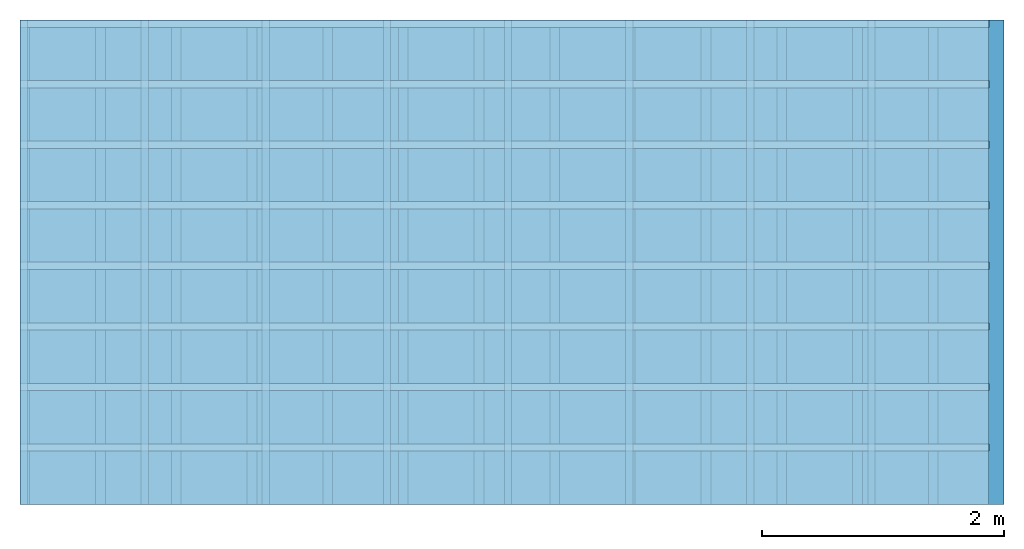
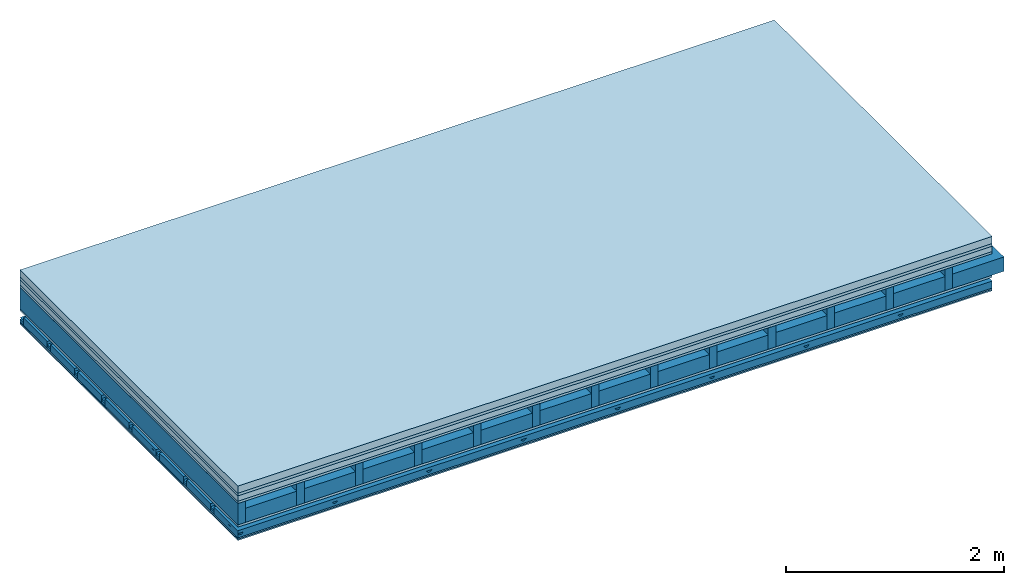
# One storey: 7 plates, 5 members, 1 element without a shape of its own.
"""IFC4 building model written with IfcOpenShell, lengths in metres."""

from ifc_helpers import new_model, si_unit, derived_unit, direction, frame, frame_2d, origin, origin_with_axes, place, context, project, spatial, polyline, rectangle, outline, extrude, material, layer, layer_set, type_object, element, aggregate, save


model = new_model("IFC4")

# Units and contexts
plan_context = context("Plan", 3, precision=1e-05, world=origin(), true_north=direction((0.0, 1.0)))
model_context = context("Model", 3, precision=1e-05, world=origin(), true_north=direction((0.0, 1.0)))
ifc_project = project(units=[si_unit("LENGTHUNIT", "METRE"), derived_unit("SOUNDPRESSUREUNIT", [(si_unit("PRESSUREUNIT", "PASCAL", prefix="MICRO"), 0)]), si_unit("ENERGYUNIT", "JOULE", prefix="MEGA"), si_unit("MASSUNIT", "GRAM", prefix="KILO"), derived_unit("THERMALTRANSMITTANCEUNIT", [(si_unit("POWERUNIT", "WATT"), 1), (si_unit("AREAUNIT", "SQUARE_METRE"), -1), (si_unit("THERMODYNAMICTEMPERATUREUNIT", "KELVIN"), -1)]), derived_unit("AREADENSITYUNIT", [(si_unit("MASSUNIT", "GRAM", prefix="KILO"), 1), (si_unit("AREAUNIT", "SQUARE_METRE"), -1)]), derived_unit("USERDEFINED", [(si_unit("ENERGYUNIT", "JOULE", prefix="MEGA"), 1), (si_unit("AREAUNIT", "SQUARE_METRE"), -1)])], contexts=[plan_context, model_context])

# Site, building, storey
site = spatial("IfcSite", under=ifc_project)
building_placement = place(None, origin())
building = spatial("IfcBuilding", under=site, at=building_placement)
storey_placement = place(building_placement, origin())
storey = spatial("IfcBuildingStorey", under=building, at=storey_placement)

# Slab, members, plates
ifc_material_1 = material(Name="Cement screed", Category="04.006")
ifc_layer_1 = layer(ifc_material_1, 0.08, Name="On-material")
ifc_material_2 = material()
ifc_layer_2 = layer(ifc_material_2, 0.03, Name="Impact sound insulation")
ifc_material_3 = material(Name="Cement panels, glued on sub-floor", Category="02.007")
ifc_layer_3 = layer(ifc_material_3, 0.06, Name="on Supporting structure")
ifc_material_4 = material(Category="07.001")
ifc_layer_4 = layer(ifc_material_4, 0.025, Name="Sub-floor")
ifc_material_5 = material(Name="Rigid, of the art")
ifc_layer_5 = layer(ifc_material_5, 0.0, Name="Bond")
ifc_layer_6 = layer(None, 0.24, Name="Supporting structure")
ifc_layer_7 = layer(ifc_material_5, 0.0, Name="Bond")
ifc_layer_8 = layer(ifc_material_4, 0.025, Name="Lower layer 1")
ifc_layer_9 = layer(None, 0.093, Name="Coupling")
ifc_layer_10 = layer(None, 0.027, Name="Battens / profiles")
ifc_material_6 = material(Name="Plasterboard type A", Category="03.008")
ifc_layer_11 = layer(ifc_material_6, 0.015, Name="Ceiling covering 1st layer")
ifc_layer_12 = layer(ifc_material_6, 0.015, Name="Ceiling covering layer 2")
ifc_material_7 = material(Name="joints", Category="04.017")
ifc_layer_13 = layer(ifc_material_7, 0.0, Name="Surface / treatment")
ifc_layer_set = layer_set([ifc_layer_1, ifc_layer_2, ifc_layer_3, ifc_layer_4, ifc_layer_5, ifc_layer_6, ifc_layer_7, ifc_layer_8, ifc_layer_9, ifc_layer_10, ifc_layer_11, ifc_layer_12, ifc_layer_13])
slab_type = type_object("IfcSlabType", Name="A0583", PredefinedType="NOTDEFINED", material=ifc_layer_set)
slab_placement = place(None, frame((0.0, 0.0, 0.0), z_axis=(0.0, 0.0, -1.0), x_axis=(1.0, 0.0, 0.0)))
slab = element("IfcSlab", 1, at=slab_placement, inside=storey, type_object=slab_type, material=ifc_layer_set, Name="Slab #1")
ifc_material_8 = material()
member_1_placement = place(slab_placement, origin())
member_1 = element("IfcMember", 2, at=member_1_placement, material=ifc_material_8, Name="Supporting structure", context=plan_context, shape_type="SweptSolid", body=[
    extrude(rectangle(XDim=0.08, YDim=0.24, at=frame_2d((0.04, 0.12), x_axis=(1.0, 0.0))), frame((0.0, 4.0, 0.195), z_axis=(0.0, -1.0, 0.0), x_axis=(1.0, 0.0, 0.0)), (0.0, 0.0, 1.0), 4.0),
    extrude(rectangle(XDim=0.08, YDim=0.24, at=frame_2d((0.04, 0.12), x_axis=(1.0, 0.0))), frame((0.625, 4.0, 0.195), z_axis=(0.0, -1.0, 0.0), x_axis=(1.0, 0.0, 0.0)), (0.0, 0.0, 1.0), 4.0),
    extrude(rectangle(XDim=0.08, YDim=0.24, at=frame_2d((0.04, 0.12), x_axis=(1.0, 0.0))), frame((1.25, 4.0, 0.195), z_axis=(0.0, -1.0, 0.0), x_axis=(1.0, 0.0, 0.0)), (0.0, 0.0, 1.0), 4.0),
    extrude(rectangle(XDim=0.08, YDim=0.24, at=frame_2d((0.04, 0.12), x_axis=(1.0, 0.0))), frame((1.875, 4.0, 0.195), z_axis=(0.0, -1.0, 0.0), x_axis=(1.0, 0.0, 0.0)), (0.0, 0.0, 1.0), 4.0),
    extrude(rectangle(XDim=0.08, YDim=0.24, at=frame_2d((0.04, 0.12), x_axis=(1.0, 0.0))), frame((2.5, 4.0, 0.195), z_axis=(0.0, -1.0, 0.0), x_axis=(1.0, 0.0, 0.0)), (0.0, 0.0, 1.0), 4.0),
    extrude(rectangle(XDim=0.08, YDim=0.24, at=frame_2d((0.04, 0.12), x_axis=(1.0, 0.0))), frame((3.125, 4.0, 0.195), z_axis=(0.0, -1.0, 0.0), x_axis=(1.0, 0.0, 0.0)), (0.0, 0.0, 1.0), 4.0),
    extrude(rectangle(XDim=0.08, YDim=0.24, at=frame_2d((0.04, 0.12), x_axis=(1.0, 0.0))), frame((3.75, 4.0, 0.195), z_axis=(0.0, -1.0, 0.0), x_axis=(1.0, 0.0, 0.0)), (0.0, 0.0, 1.0), 4.0),
    extrude(rectangle(XDim=0.08, YDim=0.24, at=frame_2d((0.04, 0.12), x_axis=(1.0, 0.0))), frame((4.375, 4.0, 0.195), z_axis=(0.0, -1.0, 0.0), x_axis=(1.0, 0.0, 0.0)), (0.0, 0.0, 1.0), 4.0),
    extrude(rectangle(XDim=0.08, YDim=0.24, at=frame_2d((0.04, 0.12), x_axis=(1.0, 0.0))), frame((5.0, 4.0, 0.195), z_axis=(0.0, -1.0, 0.0), x_axis=(1.0, 0.0, 0.0)), (0.0, 0.0, 1.0), 4.0),
    extrude(rectangle(XDim=0.08, YDim=0.24, at=frame_2d((0.04, 0.12), x_axis=(1.0, 0.0))), frame((5.625, 4.0, 0.195), z_axis=(0.0, -1.0, 0.0), x_axis=(1.0, 0.0, 0.0)), (0.0, 0.0, 1.0), 4.0),
    extrude(rectangle(XDim=0.08, YDim=0.24, at=frame_2d((0.04, 0.12), x_axis=(1.0, 0.0))), frame((6.25, 4.0, 0.195), z_axis=(0.0, -1.0, 0.0), x_axis=(1.0, 0.0, 0.0)), (0.0, 0.0, 1.0), 4.0),
    extrude(rectangle(XDim=0.08, YDim=0.24, at=frame_2d((0.04, 0.12), x_axis=(1.0, 0.0))), frame((6.875, 4.0, 0.195), z_axis=(0.0, -1.0, 0.0), x_axis=(1.0, 0.0, 0.0)), (0.0, 0.0, 1.0), 4.0),
    extrude(rectangle(XDim=0.08, YDim=0.24, at=frame_2d((0.04, 0.12), x_axis=(1.0, 0.0))), frame((7.5, 4.0, 0.195), z_axis=(0.0, -1.0, 0.0), x_axis=(1.0, 0.0, 0.0)), (0.0, 0.0, 1.0), 4.0),
])
ifc_material_9 = material()
member_2_placement = place(slab_placement, origin())
member_2 = element("IfcMember", 3, at=member_2_placement, material=ifc_material_9, Name="Cavity", context=plan_context, shape_type="SweptSolid", body=[
    extrude(rectangle(XDim=0.545, YDim=0.16, at=frame_2d((0.2725, 0.08), x_axis=(1.0, 0.0))), frame((0.08, 4.0, 0.275), z_axis=(0.0, -1.0, 0.0), x_axis=(1.0, 0.0, 0.0)), (0.0, 0.0, 1.0), 4.0),
    extrude(rectangle(XDim=0.545, YDim=0.16, at=frame_2d((0.2725, 0.08), x_axis=(1.0, 0.0))), frame((0.705, 4.0, 0.275), z_axis=(0.0, -1.0, 0.0), x_axis=(1.0, 0.0, 0.0)), (0.0, 0.0, 1.0), 4.0),
    extrude(rectangle(XDim=0.545, YDim=0.16, at=frame_2d((0.2725, 0.08), x_axis=(1.0, 0.0))), frame((1.33, 4.0, 0.275), z_axis=(0.0, -1.0, 0.0), x_axis=(1.0, 0.0, 0.0)), (0.0, 0.0, 1.0), 4.0),
    extrude(rectangle(XDim=0.545, YDim=0.16, at=frame_2d((0.2725, 0.08), x_axis=(1.0, 0.0))), frame((1.955, 4.0, 0.275), z_axis=(0.0, -1.0, 0.0), x_axis=(1.0, 0.0, 0.0)), (0.0, 0.0, 1.0), 4.0),
    extrude(rectangle(XDim=0.545, YDim=0.16, at=frame_2d((0.2725, 0.08), x_axis=(1.0, 0.0))), frame((2.58, 4.0, 0.275), z_axis=(0.0, -1.0, 0.0), x_axis=(1.0, 0.0, 0.0)), (0.0, 0.0, 1.0), 4.0),
    extrude(rectangle(XDim=0.545, YDim=0.16, at=frame_2d((0.2725, 0.08), x_axis=(1.0, 0.0))), frame((3.205, 4.0, 0.275), z_axis=(0.0, -1.0, 0.0), x_axis=(1.0, 0.0, 0.0)), (0.0, 0.0, 1.0), 4.0),
    extrude(rectangle(XDim=0.545, YDim=0.16, at=frame_2d((0.2725, 0.08), x_axis=(1.0, 0.0))), frame((3.83, 4.0, 0.275), z_axis=(0.0, -1.0, 0.0), x_axis=(1.0, 0.0, 0.0)), (0.0, 0.0, 1.0), 4.0),
    extrude(rectangle(XDim=0.545, YDim=0.16, at=frame_2d((0.2725, 0.08), x_axis=(1.0, 0.0))), frame((4.455, 4.0, 0.275), z_axis=(0.0, -1.0, 0.0), x_axis=(1.0, 0.0, 0.0)), (0.0, 0.0, 1.0), 4.0),
    extrude(rectangle(XDim=0.545, YDim=0.16, at=frame_2d((0.2725, 0.08), x_axis=(1.0, 0.0))), frame((5.08, 4.0, 0.275), z_axis=(0.0, -1.0, 0.0), x_axis=(1.0, 0.0, 0.0)), (0.0, 0.0, 1.0), 4.0),
    extrude(rectangle(XDim=0.545, YDim=0.16, at=frame_2d((0.2725, 0.08), x_axis=(1.0, 0.0))), frame((5.705, 4.0, 0.275), z_axis=(0.0, -1.0, 0.0), x_axis=(1.0, 0.0, 0.0)), (0.0, 0.0, 1.0), 4.0),
    extrude(rectangle(XDim=0.545, YDim=0.16, at=frame_2d((0.2725, 0.08), x_axis=(1.0, 0.0))), frame((6.33, 4.0, 0.275), z_axis=(0.0, -1.0, 0.0), x_axis=(1.0, 0.0, 0.0)), (0.0, 0.0, 1.0), 4.0),
    extrude(rectangle(XDim=0.545, YDim=0.16, at=frame_2d((0.2725, 0.08), x_axis=(1.0, 0.0))), frame((6.955, 4.0, 0.275), z_axis=(0.0, -1.0, 0.0), x_axis=(1.0, 0.0, 0.0)), (0.0, 0.0, 1.0), 4.0),
    extrude(rectangle(XDim=0.545, YDim=0.16, at=frame_2d((0.2725, 0.08), x_axis=(1.0, 0.0))), frame((7.58, 4.0, 0.275), z_axis=(0.0, -1.0, 0.0), x_axis=(1.0, 0.0, 0.0)), (0.0, 0.0, 1.0), 4.0),
])
ifc_material_10 = material()
member_3_placement = place(slab_placement, origin())
member_3 = element("IfcMember", 4, at=member_3_placement, material=ifc_material_10, Name="Coupling", context=plan_context, shape_type="SweptSolid", body=[
    extrude(outline(polyline([(0.0, 0.0), (0.06, 0.0), (0.04, 0.02), (0.02, 0.02), (0.0, 0.0)])), frame((0.0, 4.0, 0.533), z_axis=(0.0, -1.0, 0.0), x_axis=(1.0, 0.0, 0.0)), (0.0, 0.0, 1.0), 4.0),
    extrude(outline(polyline([(0.0, 0.0), (0.06, 0.0), (0.04, 0.02), (0.02, 0.02), (0.0, 0.0)])), frame((1.0, 4.0, 0.533), z_axis=(0.0, -1.0, 0.0), x_axis=(1.0, 0.0, 0.0)), (0.0, 0.0, 1.0), 4.0),
    extrude(outline(polyline([(0.0, 0.0), (0.06, 0.0), (0.04, 0.02), (0.02, 0.02), (0.0, 0.0)])), frame((2.0, 4.0, 0.533), z_axis=(0.0, -1.0, 0.0), x_axis=(1.0, 0.0, 0.0)), (0.0, 0.0, 1.0), 4.0),
    extrude(outline(polyline([(0.0, 0.0), (0.06, 0.0), (0.04, 0.02), (0.02, 0.02), (0.0, 0.0)])), frame((3.0, 4.0, 0.533), z_axis=(0.0, -1.0, 0.0), x_axis=(1.0, 0.0, 0.0)), (0.0, 0.0, 1.0), 4.0),
    extrude(outline(polyline([(0.0, 0.0), (0.06, 0.0), (0.04, 0.02), (0.02, 0.02), (0.0, 0.0)])), frame((4.0, 4.0, 0.533), z_axis=(0.0, -1.0, 0.0), x_axis=(1.0, 0.0, 0.0)), (0.0, 0.0, 1.0), 4.0),
    extrude(outline(polyline([(0.0, 0.0), (0.06, 0.0), (0.04, 0.02), (0.02, 0.02), (0.0, 0.0)])), frame((5.0, 4.0, 0.533), z_axis=(0.0, -1.0, 0.0), x_axis=(1.0, 0.0, 0.0)), (0.0, 0.0, 1.0), 4.0),
    extrude(outline(polyline([(0.0, 0.0), (0.06, 0.0), (0.04, 0.02), (0.02, 0.02), (0.0, 0.0)])), frame((6.0, 4.0, 0.533), z_axis=(0.0, -1.0, 0.0), x_axis=(1.0, 0.0, 0.0)), (0.0, 0.0, 1.0), 4.0),
    extrude(outline(polyline([(0.0, 0.0), (0.06, 0.0), (0.04, 0.02), (0.02, 0.02), (0.0, 0.0)])), frame((7.0, 4.0, 0.533), z_axis=(0.0, -1.0, 0.0), x_axis=(1.0, 0.0, 0.0)), (0.0, 0.0, 1.0), 4.0),
])
ifc_material_11 = material()
member_4_placement = place(slab_placement, origin())
member_4 = element("IfcMember", 5, at=member_4_placement, material=ifc_material_11, Name="Battens / profiles", context=plan_context, shape_type="SweptSolid", body=[
    extrude(rectangle(XDim=0.06, YDim=0.027, at=frame_2d((0.03, 0.0135), x_axis=(1.0, 0.0))), frame((0.0, 0.0, 0.553), z_axis=(1.0, 0.0, 0.0), x_axis=(0.0, 1.0, 0.0)), (0.0, 0.0, 1.0), 8.0),
    extrude(rectangle(XDim=0.06, YDim=0.027, at=frame_2d((0.03, 0.0135), x_axis=(1.0, 0.0))), frame((0.0, 0.5, 0.553), z_axis=(1.0, 0.0, 0.0), x_axis=(0.0, 1.0, 0.0)), (0.0, 0.0, 1.0), 8.0),
    extrude(rectangle(XDim=0.06, YDim=0.027, at=frame_2d((0.03, 0.0135), x_axis=(1.0, 0.0))), frame((0.0, 1.0, 0.553), z_axis=(1.0, 0.0, 0.0), x_axis=(0.0, 1.0, 0.0)), (0.0, 0.0, 1.0), 8.0),
    extrude(rectangle(XDim=0.06, YDim=0.027, at=frame_2d((0.03, 0.0135), x_axis=(1.0, 0.0))), frame((0.0, 1.5, 0.553), z_axis=(1.0, 0.0, 0.0), x_axis=(0.0, 1.0, 0.0)), (0.0, 0.0, 1.0), 8.0),
    extrude(rectangle(XDim=0.06, YDim=0.027, at=frame_2d((0.03, 0.0135), x_axis=(1.0, 0.0))), frame((0.0, 2.0, 0.553), z_axis=(1.0, 0.0, 0.0), x_axis=(0.0, 1.0, 0.0)), (0.0, 0.0, 1.0), 8.0),
    extrude(rectangle(XDim=0.06, YDim=0.027, at=frame_2d((0.03, 0.0135), x_axis=(1.0, 0.0))), frame((0.0, 2.5, 0.553), z_axis=(1.0, 0.0, 0.0), x_axis=(0.0, 1.0, 0.0)), (0.0, 0.0, 1.0), 8.0),
    extrude(rectangle(XDim=0.06, YDim=0.027, at=frame_2d((0.03, 0.0135), x_axis=(1.0, 0.0))), frame((0.0, 3.0, 0.553), z_axis=(1.0, 0.0, 0.0), x_axis=(0.0, 1.0, 0.0)), (0.0, 0.0, 1.0), 8.0),
    extrude(rectangle(XDim=0.06, YDim=0.027, at=frame_2d((0.03, 0.0135), x_axis=(1.0, 0.0))), frame((0.0, 3.5, 0.553), z_axis=(1.0, 0.0, 0.0), x_axis=(0.0, 1.0, 0.0)), (0.0, 0.0, 1.0), 8.0),
])
member_5_placement = place(slab_placement, origin())
member_5 = element("IfcMember", 6, at=member_5_placement, material=ifc_material_9, Name="Cavity", context=plan_context, shape_type="SweptSolid", body=[
    extrude(rectangle(XDim=0.44, YDim=0.08, at=frame_2d((0.22, 0.04), x_axis=(1.0, 0.0))), frame((0.0, 0.06, 0.5), z_axis=(1.0, 0.0, 0.0), x_axis=(0.0, 1.0, 0.0)), (0.0, 0.0, 1.0), 8.0),
    extrude(rectangle(XDim=0.44, YDim=0.08, at=frame_2d((0.22, 0.04), x_axis=(1.0, 0.0))), frame((0.0, 0.56, 0.5), z_axis=(1.0, 0.0, 0.0), x_axis=(0.0, 1.0, 0.0)), (0.0, 0.0, 1.0), 8.0),
    extrude(rectangle(XDim=0.44, YDim=0.08, at=frame_2d((0.22, 0.04), x_axis=(1.0, 0.0))), frame((0.0, 1.06, 0.5), z_axis=(1.0, 0.0, 0.0), x_axis=(0.0, 1.0, 0.0)), (0.0, 0.0, 1.0), 8.0),
    extrude(rectangle(XDim=0.44, YDim=0.08, at=frame_2d((0.22, 0.04), x_axis=(1.0, 0.0))), frame((0.0, 1.56, 0.5), z_axis=(1.0, 0.0, 0.0), x_axis=(0.0, 1.0, 0.0)), (0.0, 0.0, 1.0), 8.0),
    extrude(rectangle(XDim=0.44, YDim=0.08, at=frame_2d((0.22, 0.04), x_axis=(1.0, 0.0))), frame((0.0, 2.06, 0.5), z_axis=(1.0, 0.0, 0.0), x_axis=(0.0, 1.0, 0.0)), (0.0, 0.0, 1.0), 8.0),
    extrude(rectangle(XDim=0.44, YDim=0.08, at=frame_2d((0.22, 0.04), x_axis=(1.0, 0.0))), frame((0.0, 2.56, 0.5), z_axis=(1.0, 0.0, 0.0), x_axis=(0.0, 1.0, 0.0)), (0.0, 0.0, 1.0), 8.0),
    extrude(rectangle(XDim=0.44, YDim=0.08, at=frame_2d((0.22, 0.04), x_axis=(1.0, 0.0))), frame((0.0, 3.06, 0.5), z_axis=(1.0, 0.0, 0.0), x_axis=(0.0, 1.0, 0.0)), (0.0, 0.0, 1.0), 8.0),
    extrude(rectangle(XDim=0.44, YDim=0.08, at=frame_2d((0.22, 0.04), x_axis=(1.0, 0.0))), frame((0.0, 3.56, 0.5), z_axis=(1.0, 0.0, 0.0), x_axis=(0.0, 1.0, 0.0)), (0.0, 0.0, 1.0), 8.0),
])
plate_1_placement = place(slab_placement, origin())
plate_1 = element("IfcPlate", 7, at=plate_1_placement, material=ifc_material_1, Name="On-material", context=plan_context, shape_type="SweptSolid", body=[
    extrude(rectangle(XDim=8.0, YDim=4.0, at=frame_2d((4.0, 2.0), x_axis=(1.0, 0.0))), origin_with_axes(), (0.0, 0.0, 1.0), 0.08),
])
plate_2_placement = place(slab_placement, origin())
plate_2 = element("IfcPlate", 8, at=plate_2_placement, material=ifc_material_2, Name="Impact sound insulation", context=plan_context, shape_type="SweptSolid", body=[
    extrude(rectangle(XDim=8.0, YDim=4.0, at=frame_2d((4.0, 2.0), x_axis=(1.0, 0.0))), frame((0.0, 0.0, 0.08), z_axis=(0.0, 0.0, 1.0), x_axis=(1.0, 0.0, 0.0)), (0.0, 0.0, 1.0), 0.03),
])
plate_3_placement = place(slab_placement, origin())
plate_3 = element("IfcPlate", 9, at=plate_3_placement, material=ifc_material_3, Name="on Supporting structure", context=plan_context, shape_type="SweptSolid", body=[
    extrude(rectangle(XDim=8.0, YDim=4.0, at=frame_2d((4.0, 2.0), x_axis=(1.0, 0.0))), frame((0.0, 0.0, 0.11), z_axis=(0.0, 0.0, 1.0), x_axis=(1.0, 0.0, 0.0)), (0.0, 0.0, 1.0), 0.06),
])
plate_4_placement = place(slab_placement, origin())
plate_4 = element("IfcPlate", 10, at=plate_4_placement, material=ifc_material_4, Name="Sub-floor", context=plan_context, shape_type="SweptSolid", body=[
    extrude(rectangle(XDim=8.0, YDim=4.0, at=frame_2d((4.0, 2.0), x_axis=(1.0, 0.0))), frame((0.0, 0.0, 0.17), z_axis=(0.0, 0.0, 1.0), x_axis=(1.0, 0.0, 0.0)), (0.0, 0.0, 1.0), 0.025),
])
plate_5_placement = place(slab_placement, origin())
plate_5 = element("IfcPlate", 11, at=plate_5_placement, material=ifc_material_4, Name="Lower layer 1", context=plan_context, shape_type="SweptSolid", body=[
    extrude(rectangle(XDim=8.0, YDim=4.0, at=frame_2d((4.0, 2.0), x_axis=(1.0, 0.0))), frame((0.0, 0.0, 0.435), z_axis=(0.0, 0.0, 1.0), x_axis=(1.0, 0.0, 0.0)), (0.0, 0.0, 1.0), 0.025),
])
plate_6_placement = place(slab_placement, origin())
plate_6 = element("IfcPlate", 12, at=plate_6_placement, material=ifc_material_6, Name="Ceiling covering 1st layer", context=plan_context, shape_type="SweptSolid", body=[
    extrude(rectangle(XDim=8.0, YDim=4.0, at=frame_2d((4.0, 2.0), x_axis=(1.0, 0.0))), frame((0.0, 0.0, 0.58), z_axis=(0.0, 0.0, 1.0), x_axis=(1.0, 0.0, 0.0)), (0.0, 0.0, 1.0), 0.015),
])
plate_7_placement = place(slab_placement, origin())
plate_7 = element("IfcPlate", 13, at=plate_7_placement, material=ifc_material_6, Name="Ceiling covering layer 2", context=plan_context, shape_type="SweptSolid", body=[
    extrude(rectangle(XDim=8.0, YDim=4.0, at=frame_2d((4.0, 2.0), x_axis=(1.0, 0.0))), frame((0.0, 0.0, 0.595), z_axis=(0.0, 0.0, 1.0), x_axis=(1.0, 0.0, 0.0)), (0.0, 0.0, 1.0), 0.015),
])
aggregate(slab, [plate_1, plate_2, plate_3, plate_4, member_1, member_2, plate_5, member_3, member_4, member_5, plate_6, plate_7])

save(model, "model.ifc")
